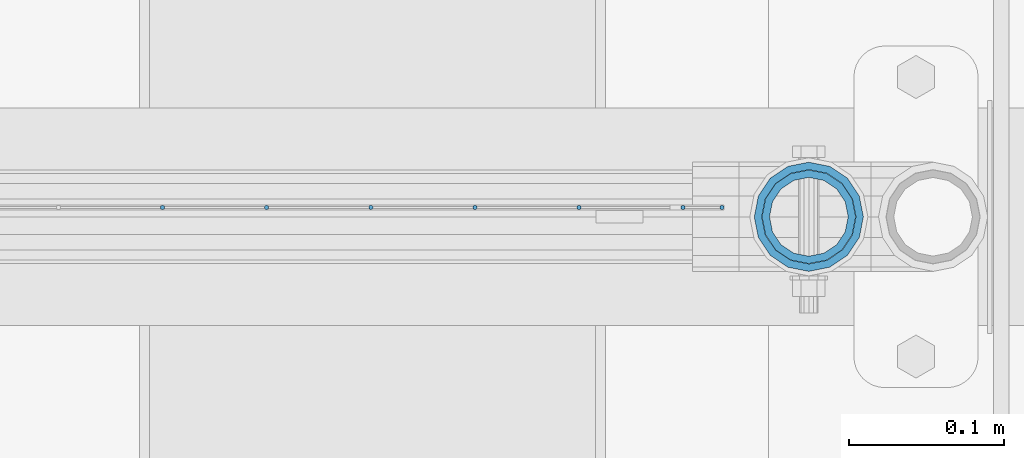
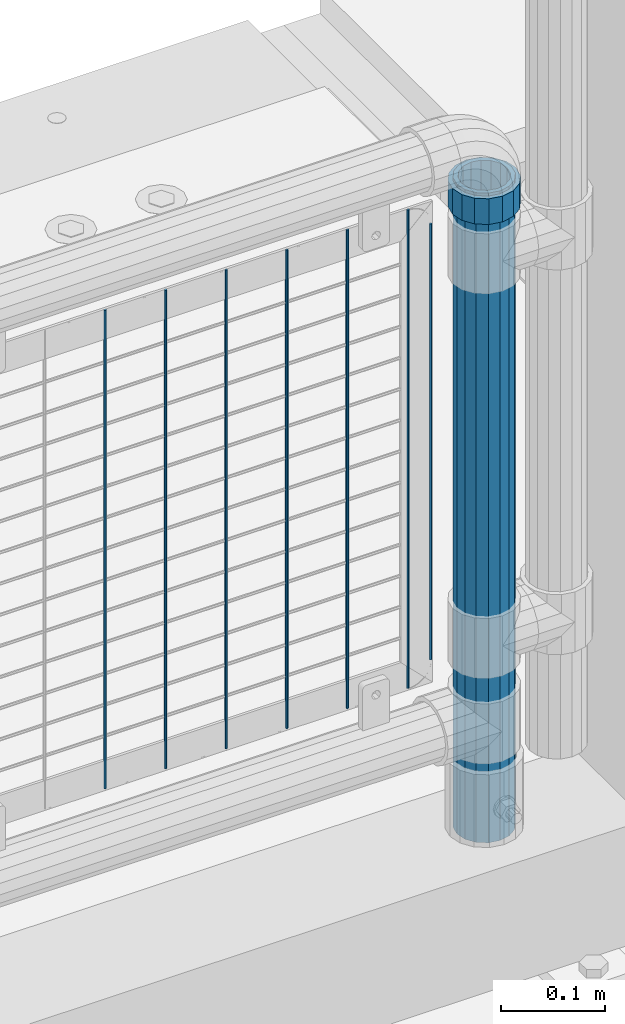
# One storey, part 83 of 193: 9 columns.
"""IFC2X3 building model written with IfcOpenShell, lengths in millimetres."""

from ifc_helpers import new_model, si_unit, frame, origin_with_axes, place, context, subcontext, project, spatial, faceted_brep, material, type_object, element, save


model = new_model("IFC2X3")

# Units and contexts
model_context = context("Model", 3, precision=1e-05, world=origin_with_axes())
body_context = subcontext(model_context, "Body", "Model", "MODEL_VIEW")
ifc_project = project(units=[si_unit("LENGTHUNIT", "METRE", prefix="MILLI"), si_unit("AREAUNIT", "SQUARE_METRE"), si_unit("VOLUMEUNIT", "CUBIC_METRE"), si_unit("MASSUNIT", "GRAM", prefix="KILO"), si_unit("TIMEUNIT", "SECOND"), si_unit("PLANEANGLEUNIT", "RADIAN"), si_unit("SOLIDANGLEUNIT", "STERADIAN"), si_unit("THERMODYNAMICTEMPERATUREUNIT", "DEGREE_CELSIUS"), si_unit("LUMINOUSINTENSITYUNIT", "LUMEN")], contexts=[model_context])

# Site, building, storey
site_placement = place(None, origin_with_axes())
site = spatial("IfcSite", under=ifc_project, at=site_placement, CompositionType="ELEMENT")
building_placement = place(site_placement, origin_with_axes())
building = spatial("IfcBuilding", under=site, at=building_placement, Name="Standard", CompositionType="ELEMENT")
storey_placement = place(building_placement, origin_with_axes())
storey = spatial("IfcBuildingStorey", under=building, at=storey_placement, Name="Undefined", CompositionType="ELEMENT", Elevation=0.0)

# Columns
ifc_material_1 = material(Name="Misc_Undefined")
column_type_1 = type_object("IfcColumnType", PredefinedType="NOTDEFINED")
column_1_placement = place(storey_placement, frame((-29019.0, 28664.5, 894.85), z_axis=(1.0, 0.0, 0.0), x_axis=(0.0, 0.0, 1.0)))
element("IfcColumn", 1, at=column_1_placement, inside=storey, type_object=column_type_1, material=ifc_material_1, context=body_context, shape_type="Brep", body=[
    faceted_brep([(0.0, -30.3499999999985, 0.0), (0.0, -28.0397438117179, 11.614442172282), (30.0, -28.0397438117179, 11.6144421722805), (30.0, -30.3499999999985, 0.0), (0.0, -21.46069080901, 21.46069080901), (30.0, -21.46069080901, 21.4606908090117), (0.0, -11.614442172282, 28.0397438117179), (30.0, -11.614442172282, 28.0397438117176), (0.0, 0.0, 30.3499999999985), (30.0, 0.0, 30.35), (0.0, 11.614442172282, 28.0397438117179), (30.0, 11.614442172282, 28.0397438117176), (0.0, 21.46069080901, 21.46069080901), (30.0, 21.46069080901, 21.4606908090117), (0.0, 28.0397438117179, 11.614442172282), (30.0, 28.0397438117179, 11.6144421722805), (0.0, 30.3499999999985, 0.0), (30.0, 30.3499999999985, 0.0), (0.0, 28.0397438117179, -11.614442172282), (30.0, 28.0397438117179, -11.6144421722805), (0.0, 21.46069080901, -21.46069080901), (30.0, 21.46069080901, -21.4606908090117), (0.0, 11.614442172282, -28.0397438117179), (30.0, 11.614442172282, -28.0397438117176), (0.0, 0.0, -30.3499999999985), (30.0, 0.0, -30.35), (0.0, -11.614442172282, -28.0397438117179), (30.0, -11.614442172282, -28.0397438117176), (0.0, -21.46069080901, -21.46069080901), (30.0, -21.46069080901, -21.4606908090117), (0.0, -28.0397438117179, -11.614442172282), (30.0, -28.0397438117179, -11.6144421722805), (0.0, -35.1500000000015, 0.0), (0.0, -32.4743655677703, -13.4513226476338), (30.0, -32.4743655677703, -13.4513226476329), (30.0, -35.1500000000015, 0.0), (0.0, -24.8548033587067, -24.8548033587067), (30.0, -24.8548033587067, -24.8548033587072), (0.0, -13.4513226476338, -32.4743655677703), (30.0, -13.4513226476338, -32.4743655677718), (0.0, 0.0, -35.1500000000015), (30.0, 0.0, -35.15), (0.0, 13.4513226476338, -32.4743655677703), (30.0, 13.4513226476338, -32.4743655677718), (0.0, 24.8548033587067, -24.8548033587067), (30.0, 24.8548033587067, -24.8548033587072), (0.0, 32.4743655677703, -13.4513226476338), (30.0, 32.4743655677703, -13.4513226476329), (0.0, 35.1500000000015, 0.0), (30.0, 35.1500000000015, 0.0), (0.0, 32.4743655677703, 13.4513226476338), (30.0, 32.4743655677703, 13.4513226476329), (0.0, 24.8548033587067, 24.8548033587067), (30.0, 24.8548033587067, 24.8548033587072), (0.0, 13.4513226476338, 32.4743655677703), (30.0, 13.4513226476338, 32.4743655677718), (0.0, 0.0, 35.1500000000015), (30.0, 0.0, 35.15), (0.0, -13.4513226476338, 32.4743655677703), (30.0, -13.4513226476338, 32.4743655677718), (0.0, -24.8548033587067, 24.8548033587067), (30.0, -24.8548033587067, 24.8548033587072), (0.0, -32.4743655677703, 13.4513226476338), (30.0, -32.4743655677703, 13.4513226476329)], [[[0, 1, 2, 3]], [[1, 4, 5, 2]], [[4, 6, 7, 5]], [[6, 8, 9, 7]], [[8, 10, 11, 9]], [[10, 12, 13, 11]], [[12, 14, 15, 13]], [[14, 16, 17, 15]], [[16, 18, 19, 17]], [[18, 20, 21, 19]], [[20, 22, 23, 21]], [[22, 24, 25, 23]], [[24, 26, 27, 25]], [[26, 28, 29, 27]], [[28, 30, 31, 29]], [[30, 0, 3, 31]], [[32, 33, 34, 35]], [[33, 36, 37, 34]], [[36, 38, 39, 37]], [[38, 40, 41, 39]], [[40, 42, 43, 41]], [[42, 44, 45, 43]], [[44, 46, 47, 45]], [[46, 48, 49, 47]], [[48, 50, 51, 49]], [[50, 52, 53, 51]], [[52, 54, 55, 53]], [[54, 56, 57, 55]], [[56, 58, 59, 57]], [[58, 60, 61, 59]], [[60, 62, 63, 61]], [[62, 32, 35, 63]], [[37, 39, 41, 43, 45, 47, 49, 51, 53, 55, 57, 59, 61, 63, 35, 34], [5, 7, 9, 11, 13, 15, 17, 19, 21, 23, 25, 27, 29, 31, 3, 2]], [[62, 60, 58, 56, 54, 52, 50, 48, 46, 44, 42, 40, 38, 36, 33, 32], [30, 28, 26, 24, 22, 20, 18, 16, 14, 12, 10, 8, 6, 4, 1, 0]]]),
])
ifc_material_2 = material()
column_type_2 = type_object("IfcColumnType", PredefinedType="NOTDEFINED")
column_2_placement = place(storey_placement, frame((-29019.0, 28664.5, 168.019999999998), z_axis=(-1.0, 0.0, 0.0), x_axis=(0.0, 0.0, 1.0)))
element("IfcColumn", 2, at=column_2_placement, inside=storey, type_object=column_type_2, material=ifc_material_2, context=body_context, shape_type="Brep", body=[
    faceted_brep([(0.0, -25.3499999999985, 0.0), (0.0, -23.4203461491597, 9.70102501045403), (760.0, -23.4203461491597, 9.70102501045403), (760.0, -25.3499999999985, 0.0), (0.0, -17.9251569030785, 17.9251569030785), (760.0, -17.9251569030785, 17.9251569030785), (0.0, -9.70102501045403, 23.4203461491597), (760.0, -9.70102501045403, 23.4203461491597), (0.0, 0.0, 25.3499999999985), (760.0, 0.0, 25.3499999999985), (0.0, 9.70102501045403, 23.4203461491597), (760.0, 9.70102501045403, 23.4203461491597), (0.0, 17.9251569030785, 17.9251569030785), (760.0, 17.9251569030785, 17.9251569030785), (0.0, 23.4203461491597, 9.70102501045403), (760.0, 23.4203461491597, 9.70102501045403), (0.0, 25.3499999999985, 0.0), (760.0, 25.3499999999985, 0.0), (0.0, 23.4203461491597, -9.70102501045403), (760.0, 23.4203461491597, -9.70102501045403), (0.0, 17.9251569030785, -17.9251569030785), (760.0, 17.9251569030785, -17.9251569030785), (0.0, 9.70102501045403, -23.4203461491597), (760.0, 9.70102501045403, -23.4203461491597), (0.0, 0.0, -25.3499999999985), (760.0, 0.0, -25.3499999999985), (0.0, -9.70102501045403, -23.4203461491597), (760.0, -9.70102501045403, -23.4203461491597), (0.0, -17.9251569030785, -17.9251569030785), (760.0, -17.9251569030785, -17.9251569030785), (0.0, -23.4203461491597, -9.70102501045403), (760.0, -23.4203461491597, -9.70102501045403), (0.0, -30.1500000000015, 0.0), (0.0, -27.8549679052157, -11.5379054858058), (760.0, -27.8549679052157, -11.5379054858058), (760.0, -30.1500000000015, 0.0), (0.0, -21.3192694527752, -21.3192694527752), (760.0, -21.3192694527752, -21.3192694527752), (0.0, -11.5379054858058, -27.8549679052157), (760.0, -11.5379054858058, -27.8549679052157), (0.0, 0.0, -30.1500000000015), (760.0, 0.0, -30.1500000000015), (0.0, 11.5379054858058, -27.8549679052157), (760.0, 11.5379054858058, -27.8549679052157), (0.0, 21.3192694527752, -21.3192694527752), (760.0, 21.3192694527752, -21.3192694527752), (0.0, 27.8549679052157, -11.5379054858058), (760.0, 27.8549679052157, -11.5379054858058), (0.0, 30.1500000000015, 0.0), (760.0, 30.1500000000015, 0.0), (0.0, 27.8549679052157, 11.5379054858058), (760.0, 27.8549679052157, 11.5379054858058), (0.0, 21.3192694527752, 21.3192694527752), (760.0, 21.3192694527752, 21.3192694527752), (0.0, 11.5379054858058, 27.8549679052157), (760.0, 11.5379054858058, 27.8549679052157), (0.0, 0.0, 30.1500000000015), (760.0, 0.0, 30.1500000000015), (0.0, -11.5379054858058, 27.8549679052157), (760.0, -11.5379054858058, 27.8549679052157), (0.0, -21.3192694527752, 21.3192694527752), (760.0, -21.3192694527752, 21.3192694527752), (0.0, -27.8549679052157, 11.5379054858058), (760.0, -27.8549679052157, 11.5379054858058)], [[[0, 1, 2, 3]], [[1, 4, 5, 2]], [[4, 6, 7, 5]], [[6, 8, 9, 7]], [[8, 10, 11, 9]], [[10, 12, 13, 11]], [[12, 14, 15, 13]], [[14, 16, 17, 15]], [[16, 18, 19, 17]], [[18, 20, 21, 19]], [[20, 22, 23, 21]], [[22, 24, 25, 23]], [[24, 26, 27, 25]], [[26, 28, 29, 27]], [[28, 30, 31, 29]], [[30, 0, 3, 31]], [[32, 33, 34, 35]], [[33, 36, 37, 34]], [[36, 38, 39, 37]], [[38, 40, 41, 39]], [[40, 42, 43, 41]], [[42, 44, 45, 43]], [[44, 46, 47, 45]], [[46, 48, 49, 47]], [[48, 50, 51, 49]], [[50, 52, 53, 51]], [[52, 54, 55, 53]], [[54, 56, 57, 55]], [[56, 58, 59, 57]], [[58, 60, 61, 59]], [[60, 62, 63, 61]], [[62, 32, 35, 63]], [[37, 39, 41, 43, 45, 47, 49, 51, 53, 55, 57, 59, 61, 63, 35, 34], [5, 7, 9, 11, 13, 15, 17, 19, 21, 23, 25, 27, 29, 31, 3, 2]], [[62, 60, 58, 56, 54, 52, 50, 48, 46, 44, 42, 40, 38, 36, 33, 32], [30, 28, 26, 24, 22, 20, 18, 16, 14, 12, 10, 8, 6, 4, 1, 0]]]),
])
column_type_3 = type_object("IfcColumnType", Name="D3", PredefinedType="NOTDEFINED")
for number, where, z_axis, x_axis in (
    (3, (-29099.9979999998, 28670.4997841009, 353.02), (-1.0, 0.0, 0.0), (0.0, 0.0, 1.0)),
    (4, (-29167.0259999998, 28670.4997983097, 353.02), (-1.0, 0.0, 0.0), (0.0, 0.0, 1.0)),
    (5, (-29234.0539999998, 28670.4998125185, 353.02), (-1.0, 0.0, 0.0), (0.0, 0.0, 1.0)),
    (6, (-29301.0819999998, 28670.4998267273, 353.02), (-1.0, 0.0, 0.0), (0.0, 0.0, 1.0)),
    (7, (-29368.1099999999, 28670.4998409362, 353.02), (-1.0, 0.0, 0.0), (0.0, 0.0, 1.0)),
    (8, (-29435.1379999999, 28670.499855145, 353.02), (-1.0, 0.0, 0.0), (0.0, 0.0, 1.0)),
):
    element("IfcColumn", number, at=place(storey_placement, frame(where, z_axis=z_axis, x_axis=x_axis)), inside=storey, type_object=column_type_3, material=ifc_material_1, ObjectType="D3", context=body_context, shape_type="Brep", body=[
        faceted_brep([(0.0, -1.49999999999636, 3.63797880709171e-12), (0.0, -0.75, -1.29903810567669), (560.0, -0.75, -1.29903810567703), (560.0, -1.5, 0.0), (0.0, 0.75, -1.29903810567669), (560.0, 0.75, -1.29903810567703), (0.0, 1.50000000000364, 7.27595761418343e-12), (560.0, 1.5, 0.0), (0.0, 0.75, 1.29903810567669), (560.0, 0.75, 1.29903810567703), (0.0, -0.75, 1.29903810567669), (560.0, -0.75, 1.29903810567703)], [[[0, 1, 2, 3]], [[1, 4, 5, 2]], [[4, 6, 7, 5]], [[6, 8, 9, 7]], [[8, 10, 11, 9]], [[10, 0, 3, 11]], [[5, 7, 9, 11, 3, 2]], [[10, 8, 6, 4, 1, 0]]]),
    ])
column_3_placement = place(storey_placement, frame((-29074.9999999999, 28670.4997788013, 378.02), z_axis=(-1.0, 0.0, 0.0), x_axis=(0.0, 0.0, 1.0)))
element("IfcColumn", 9, at=column_3_placement, inside=storey, type_object=column_type_3, material=ifc_material_1, ObjectType="D3", context=body_context, shape_type="Brep", body=[
    faceted_brep([(0.0, -1.49999999999636, 3.63797880709171e-12), (0.0, -0.75, -1.29903810567669), (510.0, -0.75, -1.29903810567703), (510.0, -1.5, 0.0), (0.0, 0.75, -1.29903810567669), (510.0, 0.75, -1.29903810567703), (0.0, 1.50000000000364, 7.27595761418343e-12), (510.0, 1.5, 0.0), (0.0, 0.75, 1.29903810567669), (510.0, 0.75, 1.29903810567703), (0.0, -0.75, 1.29903810567669), (510.0, -0.75, 1.29903810567703)], [[[0, 1, 2, 3]], [[1, 4, 5, 2]], [[4, 6, 7, 5]], [[6, 8, 9, 7]], [[8, 10, 11, 9]], [[10, 0, 3, 11]], [[5, 7, 9, 11, 3, 2]], [[10, 8, 6, 4, 1, 0]]]),
])

save(model, "model.ifc")
